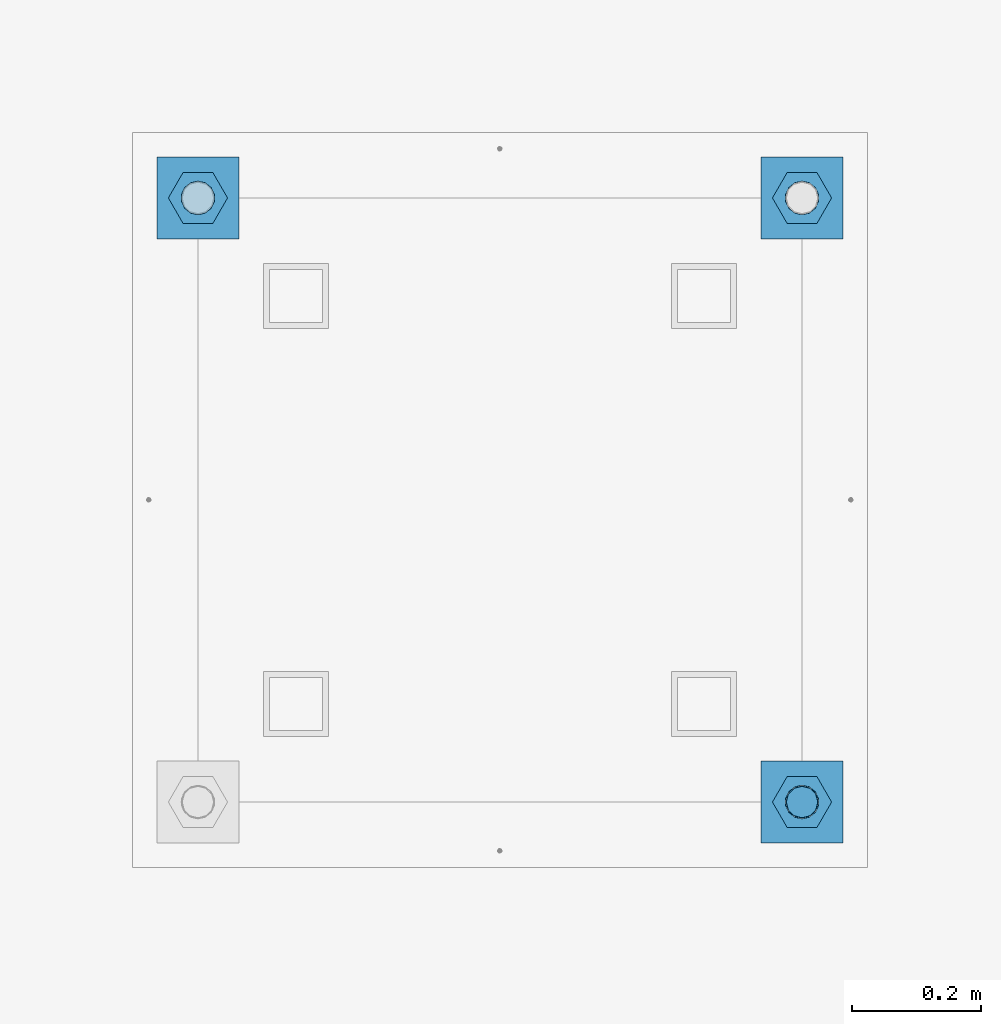
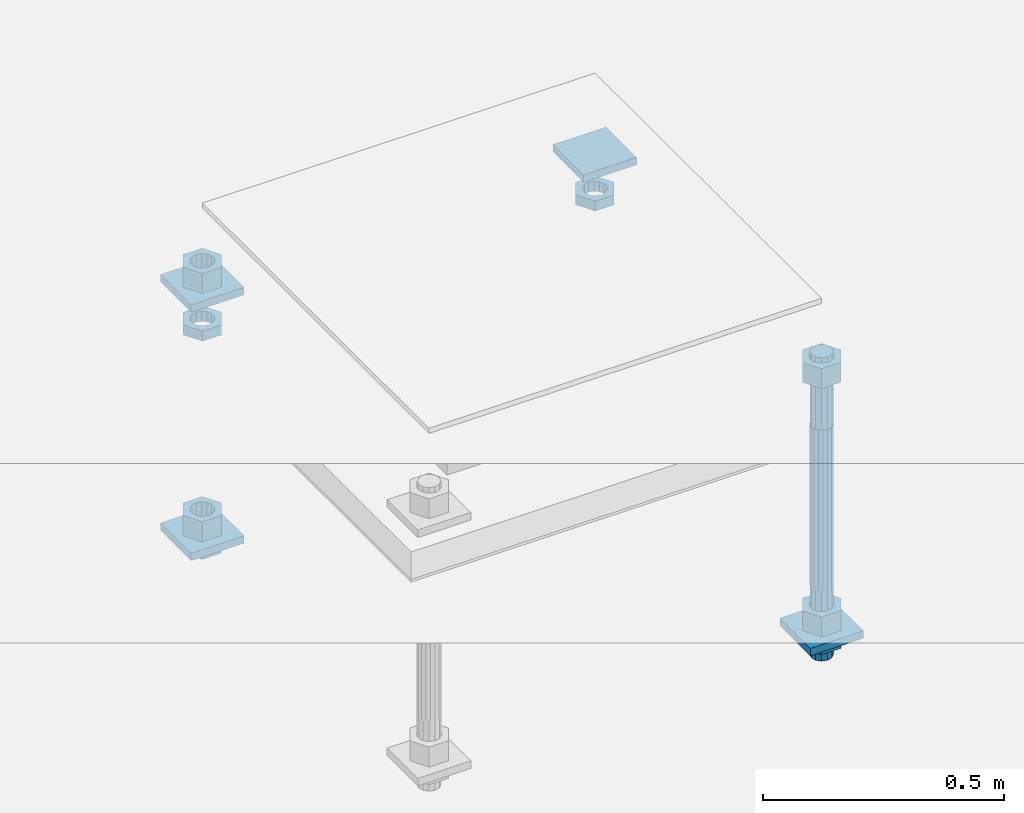
# One storey, part 2611 of 3843: 13 beams, 1 element without a shape of its own.
"""IFC2X3 building model written with IfcOpenShell, lengths in millimetres."""

import ifcopenshell
import ifcopenshell.guid

model = None  # the IFC model being written
_history = None  # IfcOwnerHistory: only IFC2X3 demands one
_inside = {}  # id of a spatial element -> (the spatial element, [elements in it])
_under = {}  # id of a project, library or spatial element -> (it, [spatial elements below it])
_declared = {}  # id of a project -> (the project, [libraries it declares])
_typed = {}  # id of a type object -> (the type object, [elements of that type])
_made_of = {}  # id of a material, layer set ... -> (it, [elements and type objects made of it])


def new_model(schema):
    """Start an empty IFC model of exactly this schema.

    Asked for "IFC4X3", IfcOpenShell would pick the latest addendum, in which some entities
    have other attributes; the version numbers below select the first issue.
    IFC2X3 requires an IfcOwnerHistory on every rooted entity: one is made here for all.
    """
    global model, _history
    if schema == "IFC4X3":
        model = ifcopenshell.file(schema_version=(4, 3, 0, 0))
    else:
        model = ifcopenshell.file(schema=schema)
    _inside.clear()
    _under.clear()
    _declared.clear()
    _typed.clear()
    _made_of.clear()
    _history = None
    if model.schema == "IFC2X3":
        org = make("IfcOrganization", Name="unknown")
        user = make(
            "IfcPersonAndOrganization",
            ThePerson=make("IfcPerson", FamilyName="unknown"),
            TheOrganization=org,
        )
        app = make(
            "IfcApplication",
            ApplicationDeveloper=org,
            Version="unknown",
            ApplicationFullName="unknown",
            ApplicationIdentifier="unknown",
        )
        _history = make(
            "IfcOwnerHistory",
            OwningUser=user,
            OwningApplication=app,
            ChangeAction="ADDED",
            CreationDate=0,
        )
    return model


def make(cls, **values):
    """One entity of the class cls with the attributes given. An attribute that is None is left unset."""
    return model.create_entity(
        cls, **{name: value for name, value in values.items() if value is not None}
    )


def rooted(cls, **values):
    """An entity with a GlobalId (a new one), such as an element, a storey or a relation."""
    return make(cls, GlobalId=ifcopenshell.guid.new(), OwnerHistory=_history, **values)


def si_unit(unit_type, name, prefix=None):
    """IfcSIUnit, for example si_unit("LENGTHUNIT", "METRE", prefix="MILLI")."""
    return make("IfcSIUnit", UnitType=unit_type, Prefix=prefix, Name=name)


def assignment(units):
    """IfcUnitAssignment: the units of a project."""
    return None if units is None else make("IfcUnitAssignment", Units=units)


def point(xyz):
    """IfcCartesianPoint."""
    return None if xyz is None else make("IfcCartesianPoint", Coordinates=xyz)


def direction(xyz):
    """IfcDirection."""
    return None if xyz is None else make("IfcDirection", DirectionRatios=xyz)


def frame(location, z_axis=None, x_axis=None):
    """IfcAxis2Placement3D, a coordinate frame: its origin and axes. An axis left out is left unset."""
    return make(
        "IfcAxis2Placement3D",
        Location=point(location),
        Axis=direction(z_axis),
        RefDirection=direction(x_axis),
    )


def origin_with_axes():
    """The frame at (0, 0, 0) with the z axis (0, 0, 1) and the x axis (1, 0, 0) written out."""
    return frame((0.0, 0.0, 0.0), z_axis=(0.0, 0.0, 1.0), x_axis=(1.0, 0.0, 0.0))


def place(relative_to, where):
    """IfcLocalPlacement: puts the frame where relative to a parent placement (None: the world)."""
    return make(
        "IfcLocalPlacement", PlacementRelTo=relative_to, RelativePlacement=where
    )


def context(
    kind, dimensions, precision=None, world=None, true_north=None, identifier=None
):
    """IfcGeometricRepresentationContext, for example the 3D "Model" context."""
    return make(
        "IfcGeometricRepresentationContext",
        ContextIdentifier=identifier,
        ContextType=kind,
        CoordinateSpaceDimension=dimensions,
        Precision=precision,
        WorldCoordinateSystem=world,
        TrueNorth=true_north,
    )


def subcontext(parent, identifier, kind, view, scale=None):
    """IfcGeometricRepresentationSubContext, for example "Body" below "Model"."""
    return make(
        "IfcGeometricRepresentationSubContext",
        ContextIdentifier=identifier,
        ContextType=kind,
        ParentContext=parent,
        TargetScale=scale,
        TargetView=view,
    )


def project(units=None, contexts=None):
    """IfcProject with its units and contexts."""
    return rooted(
        "IfcProject",
        Name="project",
        RepresentationContexts=contexts,
        UnitsInContext=assignment(units),
    )


def spatial(cls, under=None, at=None, **own):
    """A site, building, storey or space (cls), placed at a placement, below another one or the project."""
    s = rooted(cls, ObjectPlacement=at, **own)
    if under is not None:
        _under.setdefault(under.id(), (under, []))[1].append(s)
    return s


def faces_of(points, faces, orient=None, outer=None):
    """IfcFace entities. A face is a list of loops; a loop is a list of indices into points, from 0.

    orient and outer hold one flag for each loop. By default every Orientation is true, the
    first loop of a face is its IfcFaceOuterBound and the others are IfcFaceBound.
    """
    made = []
    for i, loops in enumerate(faces):
        bounds = []
        for j, loop in enumerate(loops):
            is_outer = j == 0 if outer is None else outer[i][j]
            bounds.append(
                make(
                    "IfcFaceOuterBound" if is_outer else "IfcFaceBound",
                    Bound=make("IfcPolyLoop", Polygon=[points[k] for k in loop]),
                    Orientation=True if orient is None else orient[i][j],
                )
            )
        made.append(make("IfcFace", Bounds=bounds))
    return made


def faceted_brep(points, faces, orient=None, outer=None, voids=None):
    """IfcFacetedBrep: a solid bounded by flat faces; with voids (closed shells), ...WithVoids."""
    shared = [point(p) for p in points]
    hull = make("IfcClosedShell", CfsFaces=faces_of(shared, faces, orient, outer))
    if voids is None:
        return make("IfcFacetedBrep", Outer=hull)
    return make(
        "IfcFacetedBrepWithVoids",
        Outer=hull,
        Voids=[
            make(cls, CfsFaces=faces_of(shared, fs, o, b)) for cls, fs, o, b in voids
        ],
    )


def shape(context_of_items, identifier, shape_type, items):
    """IfcShapeRepresentation: the items that make up one representation, for example the "Body"."""
    return make(
        "IfcShapeRepresentation",
        ContextOfItems=context_of_items,
        RepresentationIdentifier=identifier,
        RepresentationType=shape_type,
        Items=items,
    )


def material(Name=None, Category=None):
    """IfcMaterial."""
    return make("IfcMaterial", Name=Name, Category=Category)


def made_of(thing, what):
    """Note that an element or type object is made of a material, layer set ...; save() writes the relation."""
    if what is not None:
        _made_of.setdefault(what.id(), (what, []))[1].append(thing)
    return thing


def type_object(cls, material=None, **own):
    """A type object (cls), such as IfcWallType, which elements share."""
    return made_of(rooted(cls, **own), material)


def element(
    cls,
    number,
    at=None,
    inside=None,
    cuts=None,
    type_object=None,
    material=None,
    context=None,
    identifier="Body",
    shape_type=None,
    held_by="IfcProductDefinitionShape",
    body=None,
    shapes=None,
    **own,
):
    """One element of the class cls, such as IfcWall. Its Tag is "e" and its number.

    at: its placement. inside: the storey or other place that contains it. cuts: it is an
    opening in that element (IfcRelVoidsElement). A single representation is given by context,
    identifier, shape_type and body (its items); several are given by shapes. held_by: the class
    of the entity that holds the representations. save() writes the other relations.
    """
    e = rooted(cls, Tag="e%d" % number, ObjectPlacement=at, **own)
    if body is not None:
        shapes = [shape(context, identifier, shape_type, body)]
    if shapes is not None:
        e.Representation = make(held_by, Representations=shapes)
    if inside is not None:
        _inside.setdefault(inside.id(), (inside, []))[1].append(e)
    if cuts is not None:
        rooted(
            "IfcRelVoidsElement", RelatingBuildingElement=cuts, RelatedOpeningElement=e
        )
    if type_object is not None:
        _typed.setdefault(type_object.id(), (type_object, []))[1].append(e)
    return made_of(e, material)


def aggregate(whole, parts):
    """IfcRelAggregates: a whole, such as a stair, and the parts it consists of."""
    return rooted("IfcRelAggregates", RelatingObject=whole, RelatedObjects=parts)


def save(model, path):
    """Write the relations noted so far, then the file.

    IfcRelAggregates (storeys below a building ...), IfcRelContainedInSpatialStructure (elements
    in a storey), IfcRelDefinesByType, IfcRelAssociatesMaterial and IfcRelDeclares: one each for
    every whole, place, type object, material and project.
    """
    for whole, parts in _under.values():
        aggregate(whole, parts)
    for where, things in _inside.values():
        rooted(
            "IfcRelContainedInSpatialStructure",
            RelatedElements=things,
            RelatingStructure=where,
        )
    for kind, things in _typed.values():
        rooted("IfcRelDefinesByType", RelatedObjects=things, RelatingType=kind)
    for what, things in _made_of.values():
        rooted("IfcRelAssociatesMaterial", RelatedObjects=things, RelatingMaterial=what)
    for by, libraries in _declared.values():
        rooted("IfcRelDeclares", RelatingContext=by, RelatedDefinitions=libraries)
    model.write(path)


model = new_model("IFC2X3")

# Units and contexts
model_context = context("Model", 3, precision=1e-05, world=origin_with_axes())
body_context = subcontext(model_context, "Body", "Model", "MODEL_VIEW")
ifc_project = project(units=[si_unit("LENGTHUNIT", "METRE", prefix="MILLI"), si_unit("AREAUNIT", "SQUARE_METRE"), si_unit("VOLUMEUNIT", "CUBIC_METRE"), si_unit("MASSUNIT", "GRAM", prefix="KILO"), si_unit("TIMEUNIT", "SECOND"), si_unit("PLANEANGLEUNIT", "RADIAN"), si_unit("SOLIDANGLEUNIT", "STERADIAN"), si_unit("THERMODYNAMICTEMPERATUREUNIT", "DEGREE_CELSIUS"), si_unit("LUMINOUSINTENSITYUNIT", "LUMEN")], contexts=[model_context])

# Site, building, storey
site_placement = place(None, origin_with_axes())
site = spatial("IfcSite", under=ifc_project, at=site_placement, CompositionType="ELEMENT")
building_placement = place(site_placement, origin_with_axes())
building = spatial("IfcBuilding", under=site, at=building_placement, Name="Undefined", CompositionType="ELEMENT")
storey_placement = place(building_placement, origin_with_axes())
storey = spatial("IfcBuildingStorey", under=building, at=storey_placement, Name="Undefined", CompositionType="ELEMENT", Elevation=0.0)

# Assembly, beams
assembly_placement = place(storey_placement, origin_with_axes())
assembly = element("IfcElementAssembly", 1, at=assembly_placement, inside=storey, Name="TEMPLATE", AssemblyPlace="NOTDEFINED", PredefinedType="RIGID_FRAME")
ifc_material_1 = material(Name="STEEL/A36")
beam_type_1 = type_object("IfcBeamType", PredefinedType="NOTDEFINED")
beam_1_placement = place(assembly_placement, frame((108483.4, 29819.6000015259, 29873.575), z_axis=(1.0, 0.0, 0.0), x_axis=(0.0, 1.0, 0.0)))
beam_1 = element("IfcBeam", 2, at=beam_1_placement, type_object=beam_type_1, material=ifc_material_1, Name="WASHER_PLATE", context=body_context, shape_type="Brep", body=[
    faceted_brep([(0.0, 9.52500000000146, -63.5), (0.0, 9.52500000000146, 63.5), (127.0, 9.52500000000146, 63.5), (127.0, 9.52500000000146, -63.5), (0.0, -9.52500000000146, 63.5), (127.0, -9.52500000000146, 63.5), (0.0, -9.52500000000146, -63.5), (127.0, -9.52500000000146, -63.5)], [[[0, 1, 2, 3]], [[1, 4, 5, 2]], [[4, 6, 7, 5]], [[6, 0, 3, 7]], [[5, 7, 3, 2]], [[6, 4, 1, 0]]]),
])
beam_2_placement = place(assembly_placement, frame((109423.2, 29819.6000015259, 29873.575), z_axis=(1.0, 0.0, 0.0), x_axis=(0.0, 1.0, 0.0)))
beam_2 = element("IfcBeam", 3, at=beam_2_placement, type_object=beam_type_1, material=ifc_material_1, Name="WASHER_PLATE", context=body_context, shape_type="Brep", body=[
    faceted_brep([(0.0, 9.52500000000146, -63.5), (0.0, 9.52500000000146, 63.5), (127.0, 9.52500000000146, 63.5), (127.0, 9.52500000000146, -63.5), (0.0, -9.52500000000146, 63.5), (127.0, -9.52500000000146, 63.5), (0.0, -9.52500000000146, -63.5), (127.0, -9.52500000000146, -63.5)], [[[0, 1, 2, 3]], [[1, 4, 5, 2]], [[4, 6, 7, 5]], [[6, 0, 3, 7]], [[5, 7, 3, 2]], [[6, 4, 1, 0]]]),
])
beam_3_placement = place(assembly_placement, frame((109423.2, 28879.8000015259, 29244.925), z_axis=(1.0, 0.0, 0.0), x_axis=(0.0, 1.0, 0.0)))
beam_3 = element("IfcBeam", 4, at=beam_3_placement, type_object=beam_type_1, material=ifc_material_1, Name="WASHER_PLATE", context=body_context, shape_type="Brep", body=[
    faceted_brep([(0.0, 9.52500000000146, -63.5), (0.0, 9.52500000000146, 63.5), (127.0, 9.52500000000146, 63.5), (127.0, 9.52500000000146, -63.5), (0.0, -9.52500000000146, 63.5), (127.0, -9.52500000000146, 63.5), (0.0, -9.52500000000146, -63.5), (127.0, -9.52500000000146, -63.5)], [[[0, 1, 2, 3]], [[1, 4, 5, 2]], [[4, 6, 7, 5]], [[6, 0, 3, 7]], [[5, 7, 3, 2]], [[6, 4, 1, 0]]]),
])
beam_4_placement = place(assembly_placement, frame((108483.4, 29819.6000015259, 29244.925), z_axis=(1.0, 0.0, 0.0), x_axis=(0.0, 1.0, 0.0)))
beam_4 = element("IfcBeam", 5, at=beam_4_placement, type_object=beam_type_1, material=ifc_material_1, Name="WASHER_PLATE", context=body_context, shape_type="Brep", body=[
    faceted_brep([(0.0, 9.52500000000146, -63.5), (0.0, 9.52500000000146, 63.5), (127.0, 9.52500000000146, 63.5), (127.0, 9.52500000000146, -63.5), (0.0, -9.52500000000146, 63.5), (127.0, -9.52500000000146, 63.5), (0.0, -9.52500000000146, -63.5), (127.0, -9.52500000000146, -63.5)], [[[0, 1, 2, 3]], [[1, 4, 5, 2]], [[4, 6, 7, 5]], [[6, 0, 3, 7]], [[5, 7, 3, 2]], [[6, 4, 1, 0]]]),
])
beam_type_2 = type_object("IfcBeamType", Name="2_HALF_NUT", PredefinedType="NOTDEFINED")
beam_5_placement = place(assembly_placement, frame((108483.4, 29883.1000015259, 29787.85), z_axis=(0.0, -1.0, 0.0), x_axis=(0.0, 0.0, -1.0)))
beam_5 = element("IfcBeam", 6, at=beam_5_placement, type_object=beam_type_2, material=ifc_material_1, Name="NUT", ObjectType="2_HALF_NUT", context=body_context, shape_type="Brep", body=[
    faceted_brep([(0.0, -46.0369987487793, 0.0), (0.0, -23.0184993743896, -39.869213104248), (25.4000000000015, -23.0184993743896, -39.869213104248), (25.4000000000015, -46.0369987487793, 0.0), (0.0, 23.0184993743896, -39.869213104248), (25.4000000000015, 23.0184993743896, -39.869213104248), (0.0, 46.0369987487793, 0.0), (25.4000000000015, 46.0369987487793, 0.0), (0.0, 23.0184993743896, 39.869213104248), (25.4000000000015, 23.0184993743896, 39.869213104248), (0.0, -23.0184993743896, 39.869213104248), (25.4000000000015, -23.0184993743896, 39.869213104248), (0.0, 0.0, 26.1940002441406), (0.0, 11.3650617044477, 23.5999013092805), (25.4000000000015, 11.3650617044477, 23.5999013092805), (25.4000000000015, 0.0, 26.1940002441406), (0.0, 20.4791109456419, 16.3316083006721), (25.4000000000015, 20.4791109456419, 16.3316083006721), (0.0, 25.5370200498292, 5.82867859874386), (25.4000000000015, 25.5370200498292, 5.82867859874386), (0.0, 25.5370200498292, -5.82867859874386), (25.4000000000015, 25.5370200498292, -5.82867859874386), (0.0, 20.4791109456419, -16.3316083006721), (25.4000000000015, 20.4791109456419, -16.3316083006721), (0.0, 11.3650617044477, -23.5999013092805), (25.4000000000015, 11.3650617044477, -23.5999013092805), (0.0, 0.0, -26.1940002441406), (25.4000000000015, 0.0, -26.1940002441406), (0.0, -11.3650617044477, -23.5999013092805), (25.4000000000015, -11.3650617044477, -23.5999013092805), (0.0, -20.4791109456419, -16.3316083006721), (25.4000000000015, -20.4791109456419, -16.3316083006721), (0.0, -25.5370200498292, -5.82867859874386), (25.4000000000015, -25.5370200498292, -5.82867859874386), (0.0, -25.5370200498292, 5.82867859874386), (25.4000000000015, -25.5370200498292, 5.82867859874386), (0.0, -20.4791109456419, 16.3316083006721), (25.4000000000015, -20.4791109456419, 16.3316083006721), (0.0, -11.3650617044477, 23.5999013092805), (25.4000000000015, -11.3650617044477, 23.5999013092805)], [[[0, 1, 2, 3]], [[1, 4, 5, 2]], [[4, 6, 7, 5]], [[6, 8, 9, 7]], [[8, 10, 11, 9]], [[10, 0, 3, 11]], [[12, 13, 14, 15]], [[13, 16, 17, 14]], [[16, 18, 19, 17]], [[18, 20, 21, 19]], [[20, 22, 23, 21]], [[22, 24, 25, 23]], [[24, 26, 27, 25]], [[26, 28, 29, 27]], [[28, 30, 31, 29]], [[30, 32, 33, 31]], [[32, 34, 35, 33]], [[34, 36, 37, 35]], [[36, 38, 39, 37]], [[38, 12, 15, 39]], [[5, 7, 9, 11, 3, 2], [17, 19, 21, 23, 25, 27, 29, 31, 33, 35, 37, 39, 15, 14]], [[10, 8, 6, 4, 1, 0], [38, 36, 34, 32, 30, 28, 26, 24, 22, 20, 18, 16, 13, 12]]]),
])
beam_6_placement = place(assembly_placement, frame((109423.2, 29883.1000015259, 29787.85), z_axis=(0.0, 1.0, 0.0), x_axis=(0.0, 0.0, -1.0)))
beam_6 = element("IfcBeam", 7, at=beam_6_placement, type_object=beam_type_2, material=ifc_material_1, Name="NUT", ObjectType="2_HALF_NUT", context=body_context, shape_type="Brep", body=[
    faceted_brep([(0.0, -46.0369987487793, 0.0), (0.0, -23.0184993743896, -39.869213104248), (25.4000000000015, -23.0184993743896, -39.869213104248), (25.4000000000015, -46.0369987487793, 0.0), (0.0, 23.0184993743896, -39.869213104248), (25.4000000000015, 23.0184993743896, -39.869213104248), (0.0, 46.0369987487793, 0.0), (25.4000000000015, 46.0369987487793, 0.0), (0.0, 23.0184993743896, 39.869213104248), (25.4000000000015, 23.0184993743896, 39.869213104248), (0.0, -23.0184993743896, 39.869213104248), (25.4000000000015, -23.0184993743896, 39.869213104248), (0.0, 0.0, 26.1940002441406), (0.0, 11.3650617044477, 23.5999013092805), (25.4000000000015, 11.3650617044477, 23.5999013092805), (25.4000000000015, 0.0, 26.1940002441406), (0.0, 20.4791109456419, 16.3316083006721), (25.4000000000015, 20.4791109456419, 16.3316083006721), (0.0, 25.5370200498292, 5.82867859874386), (25.4000000000015, 25.5370200498292, 5.82867859874386), (0.0, 25.5370200498292, -5.82867859874386), (25.4000000000015, 25.5370200498292, -5.82867859874386), (0.0, 20.4791109456419, -16.3316083006721), (25.4000000000015, 20.4791109456419, -16.3316083006721), (0.0, 11.3650617044477, -23.5999013092805), (25.4000000000015, 11.3650617044477, -23.5999013092805), (0.0, 0.0, -26.1940002441406), (25.4000000000015, 0.0, -26.1940002441406), (0.0, -11.3650617044477, -23.5999013092805), (25.4000000000015, -11.3650617044477, -23.5999013092805), (0.0, -20.4791109456419, -16.3316083006721), (25.4000000000015, -20.4791109456419, -16.3316083006721), (0.0, -25.5370200498292, -5.82867859874386), (25.4000000000015, -25.5370200498292, -5.82867859874386), (0.0, -25.5370200498292, 5.82867859874386), (25.4000000000015, -25.5370200498292, 5.82867859874386), (0.0, -20.4791109456419, 16.3316083006721), (25.4000000000015, -20.4791109456419, 16.3316083006721), (0.0, -11.3650617044477, 23.5999013092805), (25.4000000000015, -11.3650617044477, 23.5999013092805)], [[[0, 1, 2, 3]], [[1, 4, 5, 2]], [[4, 6, 7, 5]], [[6, 8, 9, 7]], [[8, 10, 11, 9]], [[10, 0, 3, 11]], [[12, 13, 14, 15]], [[13, 16, 17, 14]], [[16, 18, 19, 17]], [[18, 20, 21, 19]], [[20, 22, 23, 21]], [[22, 24, 25, 23]], [[24, 26, 27, 25]], [[26, 28, 29, 27]], [[28, 30, 31, 29]], [[30, 32, 33, 31]], [[32, 34, 35, 33]], [[34, 36, 37, 35]], [[36, 38, 39, 37]], [[38, 12, 15, 39]], [[5, 7, 9, 11, 3, 2], [17, 19, 21, 23, 25, 27, 29, 31, 33, 35, 37, 39, 15, 14]], [[10, 8, 6, 4, 1, 0], [38, 36, 34, 32, 30, 28, 26, 24, 22, 20, 18, 16, 13, 12]]]),
])
beam_7_placement = place(assembly_placement, frame((109423.2, 28943.3000015259, 29235.4), z_axis=(0.0, 1.0, 0.0), x_axis=(0.0, 0.0, -1.0)))
beam_7 = element("IfcBeam", 8, at=beam_7_placement, type_object=beam_type_2, material=ifc_material_1, Name="NUT", ObjectType="2_HALF_NUT", context=body_context, shape_type="Brep", body=[
    faceted_brep([(0.0, -46.0369987487793, 0.0), (0.0, -23.0184993743896, -39.869213104248), (25.4000000000015, -23.0184993743896, -39.869213104248), (25.4000000000015, -46.0369987487793, 0.0), (0.0, 23.0184993743896, -39.869213104248), (25.4000000000015, 23.0184993743896, -39.869213104248), (0.0, 46.0369987487793, 0.0), (25.4000000000015, 46.0369987487793, 0.0), (0.0, 23.0184993743896, 39.869213104248), (25.4000000000015, 23.0184993743896, 39.869213104248), (0.0, -23.0184993743896, 39.869213104248), (25.4000000000015, -23.0184993743896, 39.869213104248), (0.0, 0.0, 26.1940002441406), (0.0, 11.3650617044477, 23.5999013092805), (25.4000000000015, 11.3650617044477, 23.5999013092805), (25.4000000000015, 0.0, 26.1940002441406), (0.0, 20.4791109456419, 16.3316083006721), (25.4000000000015, 20.4791109456419, 16.3316083006721), (0.0, 25.5370200498292, 5.82867859874386), (25.4000000000015, 25.5370200498292, 5.82867859874386), (0.0, 25.5370200498292, -5.82867859874386), (25.4000000000015, 25.5370200498292, -5.82867859874386), (0.0, 20.4791109456419, -16.3316083006721), (25.4000000000015, 20.4791109456419, -16.3316083006721), (0.0, 11.3650617044477, -23.5999013092805), (25.4000000000015, 11.3650617044477, -23.5999013092805), (0.0, 0.0, -26.1940002441406), (25.4000000000015, 0.0, -26.1940002441406), (0.0, -11.3650617044477, -23.5999013092805), (25.4000000000015, -11.3650617044477, -23.5999013092805), (0.0, -20.4791109456419, -16.3316083006721), (25.4000000000015, -20.4791109456419, -16.3316083006721), (0.0, -25.5370200498292, -5.82867859874386), (25.4000000000015, -25.5370200498292, -5.82867859874386), (0.0, -25.5370200498292, 5.82867859874386), (25.4000000000015, -25.5370200498292, 5.82867859874386), (0.0, -20.4791109456419, 16.3316083006721), (25.4000000000015, -20.4791109456419, 16.3316083006721), (0.0, -11.3650617044477, 23.5999013092805), (25.4000000000015, -11.3650617044477, 23.5999013092805)], [[[0, 1, 2, 3]], [[1, 4, 5, 2]], [[4, 6, 7, 5]], [[6, 8, 9, 7]], [[8, 10, 11, 9]], [[10, 0, 3, 11]], [[12, 13, 14, 15]], [[13, 16, 17, 14]], [[16, 18, 19, 17]], [[18, 20, 21, 19]], [[20, 22, 23, 21]], [[22, 24, 25, 23]], [[24, 26, 27, 25]], [[26, 28, 29, 27]], [[28, 30, 31, 29]], [[30, 32, 33, 31]], [[32, 34, 35, 33]], [[34, 36, 37, 35]], [[36, 38, 39, 37]], [[38, 12, 15, 39]], [[5, 7, 9, 11, 3, 2], [17, 19, 21, 23, 25, 27, 29, 31, 33, 35, 37, 39, 15, 14]], [[10, 8, 6, 4, 1, 0], [38, 36, 34, 32, 30, 28, 26, 24, 22, 20, 18, 16, 13, 12]]]),
])
beam_8_placement = place(assembly_placement, frame((108483.4, 29883.1000015259, 29235.4), z_axis=(0.0, -1.0, 0.0), x_axis=(0.0, 0.0, -1.0)))
beam_8 = element("IfcBeam", 9, at=beam_8_placement, type_object=beam_type_2, material=ifc_material_1, Name="NUT", ObjectType="2_HALF_NUT", context=body_context, shape_type="Brep", body=[
    faceted_brep([(0.0, -46.0369987487793, 0.0), (0.0, -23.0184993743896, -39.869213104248), (25.4000000000015, -23.0184993743896, -39.869213104248), (25.4000000000015, -46.0369987487793, 0.0), (0.0, 23.0184993743896, -39.869213104248), (25.4000000000015, 23.0184993743896, -39.869213104248), (0.0, 46.0369987487793, 0.0), (25.4000000000015, 46.0369987487793, 0.0), (0.0, 23.0184993743896, 39.869213104248), (25.4000000000015, 23.0184993743896, 39.869213104248), (0.0, -23.0184993743896, 39.869213104248), (25.4000000000015, -23.0184993743896, 39.869213104248), (0.0, 0.0, 26.1940002441406), (0.0, 11.3650617044477, 23.5999013092805), (25.4000000000015, 11.3650617044477, 23.5999013092805), (25.4000000000015, 0.0, 26.1940002441406), (0.0, 20.4791109456419, 16.3316083006721), (25.4000000000015, 20.4791109456419, 16.3316083006721), (0.0, 25.5370200498292, 5.82867859874386), (25.4000000000015, 25.5370200498292, 5.82867859874386), (0.0, 25.5370200498292, -5.82867859874386), (25.4000000000015, 25.5370200498292, -5.82867859874386), (0.0, 20.4791109456419, -16.3316083006721), (25.4000000000015, 20.4791109456419, -16.3316083006721), (0.0, 11.3650617044477, -23.5999013092805), (25.4000000000015, 11.3650617044477, -23.5999013092805), (0.0, 0.0, -26.1940002441406), (25.4000000000015, 0.0, -26.1940002441406), (0.0, -11.3650617044477, -23.5999013092805), (25.4000000000015, -11.3650617044477, -23.5999013092805), (0.0, -20.4791109456419, -16.3316083006721), (25.4000000000015, -20.4791109456419, -16.3316083006721), (0.0, -25.5370200498292, -5.82867859874386), (25.4000000000015, -25.5370200498292, -5.82867859874386), (0.0, -25.5370200498292, 5.82867859874386), (25.4000000000015, -25.5370200498292, 5.82867859874386), (0.0, -20.4791109456419, 16.3316083006721), (25.4000000000015, -20.4791109456419, 16.3316083006721), (0.0, -11.3650617044477, 23.5999013092805), (25.4000000000015, -11.3650617044477, 23.5999013092805)], [[[0, 1, 2, 3]], [[1, 4, 5, 2]], [[4, 6, 7, 5]], [[6, 8, 9, 7]], [[8, 10, 11, 9]], [[10, 0, 3, 11]], [[12, 13, 14, 15]], [[13, 16, 17, 14]], [[16, 18, 19, 17]], [[18, 20, 21, 19]], [[20, 22, 23, 21]], [[22, 24, 25, 23]], [[24, 26, 27, 25]], [[26, 28, 29, 27]], [[28, 30, 31, 29]], [[30, 32, 33, 31]], [[32, 34, 35, 33]], [[34, 36, 37, 35]], [[36, 38, 39, 37]], [[38, 12, 15, 39]], [[5, 7, 9, 11, 3, 2], [17, 19, 21, 23, 25, 27, 29, 31, 33, 35, 37, 39, 15, 14]], [[10, 8, 6, 4, 1, 0], [38, 36, 34, 32, 30, 28, 26, 24, 22, 20, 18, 16, 13, 12]]]),
])
beam_type_3 = type_object("IfcBeamType", Name="2_HEAVY_HEX_NUT", PredefinedType="NOTDEFINED")
beam_9_placement = place(assembly_placement, frame((109423.2, 28943.3000015259, 29933.9), z_axis=(0.0, 1.0, 0.0), x_axis=(0.0, 0.0, -1.0)))
beam_9 = element("IfcBeam", 10, at=beam_9_placement, type_object=beam_type_3, material=ifc_material_1, Name="NUT", ObjectType="2_HEAVY_HEX_NUT", context=body_context, shape_type="Brep", body=[
    faceted_brep([(0.0, -46.0369987487793, 0.0), (0.0, -23.0184993743896, -39.869213104248), (50.7999999999993, -23.0184993743896, -39.869213104248), (50.7999999999993, -46.0369987487793, 0.0), (0.0, 23.0184993743896, -39.869213104248), (50.7999999999993, 23.0184993743896, -39.869213104248), (0.0, 46.0369987487793, 0.0), (50.7999999999993, 46.0369987487793, 0.0), (0.0, 23.0184993743896, 39.869213104248), (50.7999999999993, 23.0184993743896, 39.869213104248), (0.0, -23.0184993743896, 39.869213104248), (50.7999999999993, -23.0184993743896, 39.869213104248), (0.0, 0.0, 26.1940002441406), (0.0, 11.3650617044477, 23.5999013092805), (50.7999999999993, 11.3650617044477, 23.5999013092805), (50.7999999999993, 0.0, 26.1940002441406), (0.0, 20.4791109456419, 16.3316083006721), (50.7999999999993, 20.4791109456419, 16.3316083006721), (0.0, 25.5370200498292, 5.82867859874386), (50.7999999999993, 25.5370200498292, 5.82867859874386), (0.0, 25.5370200498292, -5.82867859874386), (50.7999999999993, 25.5370200498292, -5.82867859874386), (0.0, 20.4791109456419, -16.3316083006721), (50.7999999999993, 20.4791109456419, -16.3316083006721), (0.0, 11.3650617044477, -23.5999013092805), (50.7999999999993, 11.3650617044477, -23.5999013092805), (0.0, 0.0, -26.1940002441406), (50.7999999999993, 0.0, -26.1940002441406), (0.0, -11.3650617044477, -23.5999013092805), (50.7999999999993, -11.3650617044477, -23.5999013092805), (0.0, -20.4791109456419, -16.3316083006721), (50.7999999999993, -20.4791109456419, -16.3316083006721), (0.0, -25.5370200498292, -5.82867859874386), (50.7999999999993, -25.5370200498292, -5.82867859874386), (0.0, -25.5370200498292, 5.82867859874386), (50.7999999999993, -25.5370200498292, 5.82867859874386), (0.0, -20.4791109456419, 16.3316083006721), (50.7999999999993, -20.4791109456419, 16.3316083006721), (0.0, -11.3650617044477, 23.5999013092805), (50.7999999999993, -11.3650617044477, 23.5999013092805)], [[[0, 1, 2, 3]], [[1, 4, 5, 2]], [[4, 6, 7, 5]], [[6, 8, 9, 7]], [[8, 10, 11, 9]], [[10, 0, 3, 11]], [[12, 13, 14, 15]], [[13, 16, 17, 14]], [[16, 18, 19, 17]], [[18, 20, 21, 19]], [[20, 22, 23, 21]], [[22, 24, 25, 23]], [[24, 26, 27, 25]], [[26, 28, 29, 27]], [[28, 30, 31, 29]], [[30, 32, 33, 31]], [[32, 34, 35, 33]], [[34, 36, 37, 35]], [[36, 38, 39, 37]], [[38, 12, 15, 39]], [[5, 7, 9, 11, 3, 2], [17, 19, 21, 23, 25, 27, 29, 31, 33, 35, 37, 39, 15, 14]], [[10, 8, 6, 4, 1, 0], [38, 36, 34, 32, 30, 28, 26, 24, 22, 20, 18, 16, 13, 12]]]),
])
beam_10_placement = place(assembly_placement, frame((109423.2, 28943.3000015259, 29305.25), z_axis=(0.0, 1.0, 0.0), x_axis=(0.0, 0.0, -1.0)))
beam_10 = element("IfcBeam", 11, at=beam_10_placement, type_object=beam_type_3, material=ifc_material_1, Name="NUT", ObjectType="2_HEAVY_HEX_NUT", context=body_context, shape_type="Brep", body=[
    faceted_brep([(0.0, -46.0369987487793, 0.0), (0.0, -23.0184993743896, -39.869213104248), (50.7999999999993, -23.0184993743896, -39.869213104248), (50.7999999999993, -46.0369987487793, 0.0), (0.0, 23.0184993743896, -39.869213104248), (50.7999999999993, 23.0184993743896, -39.869213104248), (0.0, 46.0369987487793, 0.0), (50.7999999999993, 46.0369987487793, 0.0), (0.0, 23.0184993743896, 39.869213104248), (50.7999999999993, 23.0184993743896, 39.869213104248), (0.0, -23.0184993743896, 39.869213104248), (50.7999999999993, -23.0184993743896, 39.869213104248), (0.0, 0.0, 26.1940002441406), (0.0, 11.3650617044477, 23.5999013092805), (50.7999999999993, 11.3650617044477, 23.5999013092805), (50.7999999999993, 0.0, 26.1940002441406), (0.0, 20.4791109456419, 16.3316083006721), (50.7999999999993, 20.4791109456419, 16.3316083006721), (0.0, 25.5370200498292, 5.82867859874386), (50.7999999999993, 25.5370200498292, 5.82867859874386), (0.0, 25.5370200498292, -5.82867859874386), (50.7999999999993, 25.5370200498292, -5.82867859874386), (0.0, 20.4791109456419, -16.3316083006721), (50.7999999999993, 20.4791109456419, -16.3316083006721), (0.0, 11.3650617044477, -23.5999013092805), (50.7999999999993, 11.3650617044477, -23.5999013092805), (0.0, 0.0, -26.1940002441406), (50.7999999999993, 0.0, -26.1940002441406), (0.0, -11.3650617044477, -23.5999013092805), (50.7999999999993, -11.3650617044477, -23.5999013092805), (0.0, -20.4791109456419, -16.3316083006721), (50.7999999999993, -20.4791109456419, -16.3316083006721), (0.0, -25.5370200498292, -5.82867859874386), (50.7999999999993, -25.5370200498292, -5.82867859874386), (0.0, -25.5370200498292, 5.82867859874386), (50.7999999999993, -25.5370200498292, 5.82867859874386), (0.0, -20.4791109456419, 16.3316083006721), (50.7999999999993, -20.4791109456419, 16.3316083006721), (0.0, -11.3650617044477, 23.5999013092805), (50.7999999999993, -11.3650617044477, 23.5999013092805)], [[[0, 1, 2, 3]], [[1, 4, 5, 2]], [[4, 6, 7, 5]], [[6, 8, 9, 7]], [[8, 10, 11, 9]], [[10, 0, 3, 11]], [[12, 13, 14, 15]], [[13, 16, 17, 14]], [[16, 18, 19, 17]], [[18, 20, 21, 19]], [[20, 22, 23, 21]], [[22, 24, 25, 23]], [[24, 26, 27, 25]], [[26, 28, 29, 27]], [[28, 30, 31, 29]], [[30, 32, 33, 31]], [[32, 34, 35, 33]], [[34, 36, 37, 35]], [[36, 38, 39, 37]], [[38, 12, 15, 39]], [[5, 7, 9, 11, 3, 2], [17, 19, 21, 23, 25, 27, 29, 31, 33, 35, 37, 39, 15, 14]], [[10, 8, 6, 4, 1, 0], [38, 36, 34, 32, 30, 28, 26, 24, 22, 20, 18, 16, 13, 12]]]),
])
beam_11_placement = place(assembly_placement, frame((108483.4, 29883.1000015259, 29933.9), z_axis=(0.0, -1.0, 0.0), x_axis=(0.0, 0.0, -1.0)))
beam_11 = element("IfcBeam", 12, at=beam_11_placement, type_object=beam_type_3, material=ifc_material_1, Name="NUT", ObjectType="2_HEAVY_HEX_NUT", context=body_context, shape_type="Brep", body=[
    faceted_brep([(0.0, -46.0369987487793, 0.0), (0.0, -23.0184993743896, -39.869213104248), (50.7999999999993, -23.0184993743896, -39.869213104248), (50.7999999999993, -46.0369987487793, 0.0), (0.0, 23.0184993743896, -39.869213104248), (50.7999999999993, 23.0184993743896, -39.869213104248), (0.0, 46.0369987487793, 0.0), (50.7999999999993, 46.0369987487793, 0.0), (0.0, 23.0184993743896, 39.869213104248), (50.7999999999993, 23.0184993743896, 39.869213104248), (0.0, -23.0184993743896, 39.869213104248), (50.7999999999993, -23.0184993743896, 39.869213104248), (0.0, 0.0, 26.1940002441406), (0.0, 11.3650617044477, 23.5999013092805), (50.7999999999993, 11.3650617044477, 23.5999013092805), (50.7999999999993, 0.0, 26.1940002441406), (0.0, 20.4791109456419, 16.3316083006721), (50.7999999999993, 20.4791109456419, 16.3316083006721), (0.0, 25.5370200498292, 5.82867859874386), (50.7999999999993, 25.5370200498292, 5.82867859874386), (0.0, 25.5370200498292, -5.82867859874386), (50.7999999999993, 25.5370200498292, -5.82867859874386), (0.0, 20.4791109456419, -16.3316083006721), (50.7999999999993, 20.4791109456419, -16.3316083006721), (0.0, 11.3650617044477, -23.5999013092805), (50.7999999999993, 11.3650617044477, -23.5999013092805), (0.0, 0.0, -26.1940002441406), (50.7999999999993, 0.0, -26.1940002441406), (0.0, -11.3650617044477, -23.5999013092805), (50.7999999999993, -11.3650617044477, -23.5999013092805), (0.0, -20.4791109456419, -16.3316083006721), (50.7999999999993, -20.4791109456419, -16.3316083006721), (0.0, -25.5370200498292, -5.82867859874386), (50.7999999999993, -25.5370200498292, -5.82867859874386), (0.0, -25.5370200498292, 5.82867859874386), (50.7999999999993, -25.5370200498292, 5.82867859874386), (0.0, -20.4791109456419, 16.3316083006721), (50.7999999999993, -20.4791109456419, 16.3316083006721), (0.0, -11.3650617044477, 23.5999013092805), (50.7999999999993, -11.3650617044477, 23.5999013092805)], [[[0, 1, 2, 3]], [[1, 4, 5, 2]], [[4, 6, 7, 5]], [[6, 8, 9, 7]], [[8, 10, 11, 9]], [[10, 0, 3, 11]], [[12, 13, 14, 15]], [[13, 16, 17, 14]], [[16, 18, 19, 17]], [[18, 20, 21, 19]], [[20, 22, 23, 21]], [[22, 24, 25, 23]], [[24, 26, 27, 25]], [[26, 28, 29, 27]], [[28, 30, 31, 29]], [[30, 32, 33, 31]], [[32, 34, 35, 33]], [[34, 36, 37, 35]], [[36, 38, 39, 37]], [[38, 12, 15, 39]], [[5, 7, 9, 11, 3, 2], [17, 19, 21, 23, 25, 27, 29, 31, 33, 35, 37, 39, 15, 14]], [[10, 8, 6, 4, 1, 0], [38, 36, 34, 32, 30, 28, 26, 24, 22, 20, 18, 16, 13, 12]]]),
])
beam_12_placement = place(assembly_placement, frame((108483.4, 29883.1000015259, 29305.25), z_axis=(0.0, -1.0, 0.0), x_axis=(0.0, 0.0, -1.0)))
beam_12 = element("IfcBeam", 13, at=beam_12_placement, type_object=beam_type_3, material=ifc_material_1, Name="NUT", ObjectType="2_HEAVY_HEX_NUT", context=body_context, shape_type="Brep", body=[
    faceted_brep([(0.0, -46.0369987487793, 0.0), (0.0, -23.0184993743896, -39.869213104248), (50.7999999999993, -23.0184993743896, -39.869213104248), (50.7999999999993, -46.0369987487793, 0.0), (0.0, 23.0184993743896, -39.869213104248), (50.7999999999993, 23.0184993743896, -39.869213104248), (0.0, 46.0369987487793, 0.0), (50.7999999999993, 46.0369987487793, 0.0), (0.0, 23.0184993743896, 39.869213104248), (50.7999999999993, 23.0184993743896, 39.869213104248), (0.0, -23.0184993743896, 39.869213104248), (50.7999999999993, -23.0184993743896, 39.869213104248), (0.0, 0.0, 26.1940002441406), (0.0, 11.3650617044477, 23.5999013092805), (50.7999999999993, 11.3650617044477, 23.5999013092805), (50.7999999999993, 0.0, 26.1940002441406), (0.0, 20.4791109456419, 16.3316083006721), (50.7999999999993, 20.4791109456419, 16.3316083006721), (0.0, 25.5370200498292, 5.82867859874386), (50.7999999999993, 25.5370200498292, 5.82867859874386), (0.0, 25.5370200498292, -5.82867859874386), (50.7999999999993, 25.5370200498292, -5.82867859874386), (0.0, 20.4791109456419, -16.3316083006721), (50.7999999999993, 20.4791109456419, -16.3316083006721), (0.0, 11.3650617044477, -23.5999013092805), (50.7999999999993, 11.3650617044477, -23.5999013092805), (0.0, 0.0, -26.1940002441406), (50.7999999999993, 0.0, -26.1940002441406), (0.0, -11.3650617044477, -23.5999013092805), (50.7999999999993, -11.3650617044477, -23.5999013092805), (0.0, -20.4791109456419, -16.3316083006721), (50.7999999999993, -20.4791109456419, -16.3316083006721), (0.0, -25.5370200498292, -5.82867859874386), (50.7999999999993, -25.5370200498292, -5.82867859874386), (0.0, -25.5370200498292, 5.82867859874386), (50.7999999999993, -25.5370200498292, 5.82867859874386), (0.0, -20.4791109456419, 16.3316083006721), (50.7999999999993, -20.4791109456419, 16.3316083006721), (0.0, -11.3650617044477, 23.5999013092805), (50.7999999999993, -11.3650617044477, 23.5999013092805)], [[[0, 1, 2, 3]], [[1, 4, 5, 2]], [[4, 6, 7, 5]], [[6, 8, 9, 7]], [[8, 10, 11, 9]], [[10, 0, 3, 11]], [[12, 13, 14, 15]], [[13, 16, 17, 14]], [[16, 18, 19, 17]], [[18, 20, 21, 19]], [[20, 22, 23, 21]], [[22, 24, 25, 23]], [[24, 26, 27, 25]], [[26, 28, 29, 27]], [[28, 30, 31, 29]], [[30, 32, 33, 31]], [[32, 34, 35, 33]], [[34, 36, 37, 35]], [[36, 38, 39, 37]], [[38, 12, 15, 39]], [[5, 7, 9, 11, 3, 2], [17, 19, 21, 23, 25, 27, 29, 31, 33, 35, 37, 39, 15, 14]], [[10, 8, 6, 4, 1, 0], [38, 36, 34, 32, 30, 28, 26, 24, 22, 20, 18, 16, 13, 12]]]),
])
ifc_material_2 = material()
beam_type_4 = type_object("IfcBeamType", PredefinedType="NOTDEFINED")
beam_13_placement = place(assembly_placement, frame((109423.2, 28943.3000015259, 29762.45), z_axis=(0.0, 1.0, 0.0), x_axis=(0.0, 0.0, -1.0)))
beam_13 = element("IfcBeam", 14, at=beam_13_placement, type_object=beam_type_4, material=ifc_material_2, Name="ANCHOR_ROD", context=body_context, shape_type="Brep", body=[
    faceted_brep([(-184.150000000001, -21.217622392709, 12.25), (-184.150000000001, -12.2499999999854, 21.2176223927163), (-184.150000000001, 1.45519152283669e-11, 24.5), (-184.150000000001, 12.2500000000146, 21.2176223927163), (-184.150000000001, 21.2176223927381, 12.25), (-184.150000000001, 24.5000000000146, 0.0), (-184.150000000001, 21.2176223927381, -12.25), (-184.150000000001, 12.2500000000146, -21.2176223927163), (-184.150000000001, 1.45519152283669e-11, -24.5), (-184.150000000001, -12.2499999999854, -21.2176223927163), (-184.150000000001, -21.217622392709, -12.25), (-184.150000000001, -24.4999999999854, 0.0), (0.0, 24.5000000000146, 0.0), (0.0, 21.2176223927381, -12.25), (0.0, 12.2500000000146, -21.2176223927163), (0.0, 1.45519152283669e-11, -24.5), (0.0, -12.2499999999854, -21.2176223927163), (0.0, -21.217622392709, -12.25), (0.0, -24.4999999999854, 0.0), (0.0, -21.217622392709, 12.25), (0.0, -12.2499999999854, 21.2176223927163), (0.0, 1.45519152283669e-11, 24.5), (0.0, 12.2500000000146, 21.2176223927163), (0.0, 21.2176223927381, 12.25), (0.0, -23.4665401257807, 9.72015918207035), (0.0, -17.9605122421344, 17.9605122421417), (0.0, -9.72015918207762, 23.466540125788), (0.0, 0.0, 25.4000000000015), (0.0, 9.72015918207762, 23.466540125788), (0.0, 17.9605122421344, 17.9605122421417), (0.0, 23.4665401257807, 9.72015918207035), (0.0, 25.3999996185303, 0.0), (0.0, 23.4665401257807, -9.72015918207035), (0.0, 17.9605122421344, -17.9605122421417), (0.0, 9.72015918207762, -23.466540125788), (0.0, 0.0, -25.4000000000015), (0.0, -9.72015918207762, -23.466540125788), (0.0, -17.9605122421344, -17.9605122421417), (0.0, -23.4665401257807, -9.72015918207035), (0.0, -25.3999996185303, 0.0), (406.399999999998, -25.3999999999942, 0.0), (406.399999999998, -23.4665401257807, 9.72015918207035), (406.399999999998, -17.9605122421344, 17.9605122421417), (406.399999999998, -9.72015918207762, 23.466540125788), (406.399999999998, 0.0, 25.4000000000015), (406.399999999998, 9.72015918207762, 23.466540125788), (406.399999999998, 17.9605122421344, 17.9605122421417), (406.399999999998, 23.4665401257807, 9.72015918207035), (406.399999999998, 25.3999999999942, 0.0), (406.399999999998, 23.4665401257807, -9.72015918207035), (406.399999999998, 17.9605122421344, -17.9605122421417), (406.399999999998, 9.72015918207762, -23.466540125788), (406.399999999998, 0.0, -25.4000000000015), (406.399999999998, -9.72015918207762, -23.466540125788), (406.399999999998, -17.9605122421344, -17.9605122421417), (406.399999999998, -23.4665401257807, -9.72015918207035), (406.399999999998, -12.2499999999854, 21.2176223927163), (406.399999999998, 1.45519152283669e-11, 24.5), (406.399999999998, 12.2500000000146, 21.2176223927163), (406.399999999998, 21.2176223927381, 12.25), (406.399999999998, 24.5000000000146, 0.0), (406.399999999998, 21.2176223927381, -12.25), (406.399999999998, 12.2500000000146, -21.2176223927163), (406.399999999998, 1.45519152283669e-11, -24.5), (406.399999999998, -12.2499999999854, -21.2176223927163), (406.399999999998, -21.217622392709, -12.25), (406.399999999998, -24.4999999999854, 0.0), (406.399999999998, -21.217622392709, 12.25), (584.200000000001, -12.2499999999854, -21.2176223927163), (584.200000000001, 1.45519152283669e-11, -24.5), (584.200000000001, 12.2500000000146, -21.2176223927163), (584.200000000001, 21.2176223927381, -12.25), (584.200000000001, 24.5000000000146, 0.0), (584.200000000001, 21.2176223927381, 12.25), (584.200000000001, 12.2500000000146, 21.2176223927163), (584.200000000001, 1.45519152283669e-11, 24.5), (584.200000000001, -12.2499999999854, 21.2176223927163), (584.200000000001, -21.217622392709, 12.25), (584.200000000001, -24.4999999999854, 0.0), (584.200000000001, -21.217622392709, -12.25)], [[[0, 1, 2, 3, 4, 5, 6, 7, 8, 9, 10, 11]], [[6, 5, 12, 13]], [[7, 6, 13, 14]], [[8, 7, 14, 15]], [[9, 8, 15, 16]], [[10, 9, 16, 17]], [[11, 10, 17, 18]], [[0, 11, 18, 19]], [[1, 0, 19, 20]], [[2, 1, 20, 21]], [[3, 2, 21, 22]], [[4, 3, 22, 23]], [[5, 4, 23, 12]], [[24, 25, 26, 27, 28, 29, 30, 31, 32, 33, 34, 35, 36, 37, 38, 39], [22, 21, 20, 19, 18, 17, 16, 15, 14, 13, 12, 23]], [[24, 39, 40, 41]], [[25, 24, 41, 42]], [[26, 25, 42, 43]], [[27, 26, 43, 44]], [[28, 27, 44, 45]], [[29, 28, 45, 46]], [[30, 29, 46, 47]], [[31, 30, 47, 48]], [[32, 31, 48, 49]], [[33, 32, 49, 50]], [[34, 33, 50, 51]], [[35, 34, 51, 52]], [[36, 35, 52, 53]], [[37, 36, 53, 54]], [[38, 37, 54, 55]], [[39, 38, 55, 40]], [[54, 53, 52, 51, 50, 49, 48, 47, 46, 45, 44, 43, 42, 41, 40, 55], [56, 57, 58, 59, 60, 61, 62, 63, 64, 65, 66, 67]], [[68, 69, 70, 71, 72, 73, 74, 75, 76, 77, 78, 79]], [[76, 75, 57, 56]], [[77, 76, 56, 67]], [[78, 77, 67, 66]], [[79, 78, 66, 65]], [[68, 79, 65, 64]], [[69, 68, 64, 63]], [[70, 69, 63, 62]], [[71, 70, 62, 61]], [[72, 71, 61, 60]], [[73, 72, 60, 59]], [[74, 73, 59, 58]], [[75, 74, 58, 57]]]),
])
aggregate(assembly, [beam_5, beam_6, beam_1, beam_2, beam_9, beam_10, beam_7, beam_3, beam_13, beam_11, beam_12, beam_8, beam_4])

save(model, "model.ifc")
